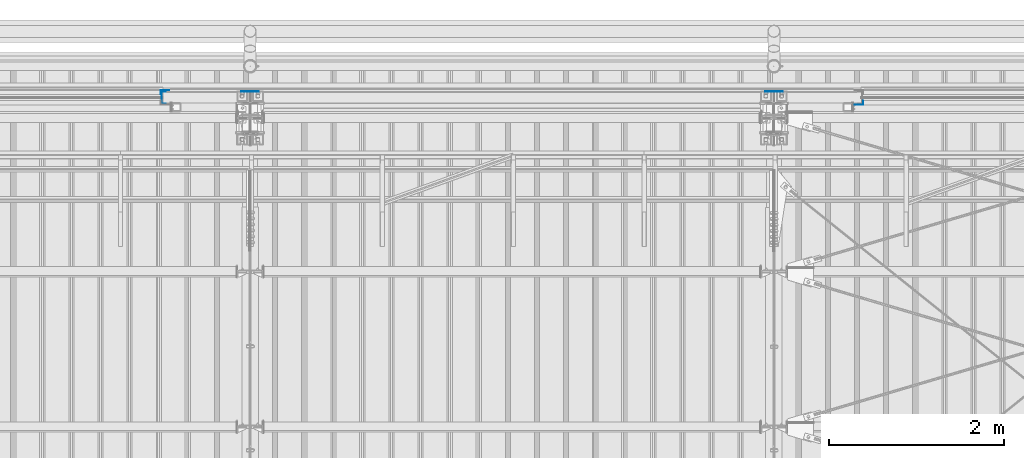
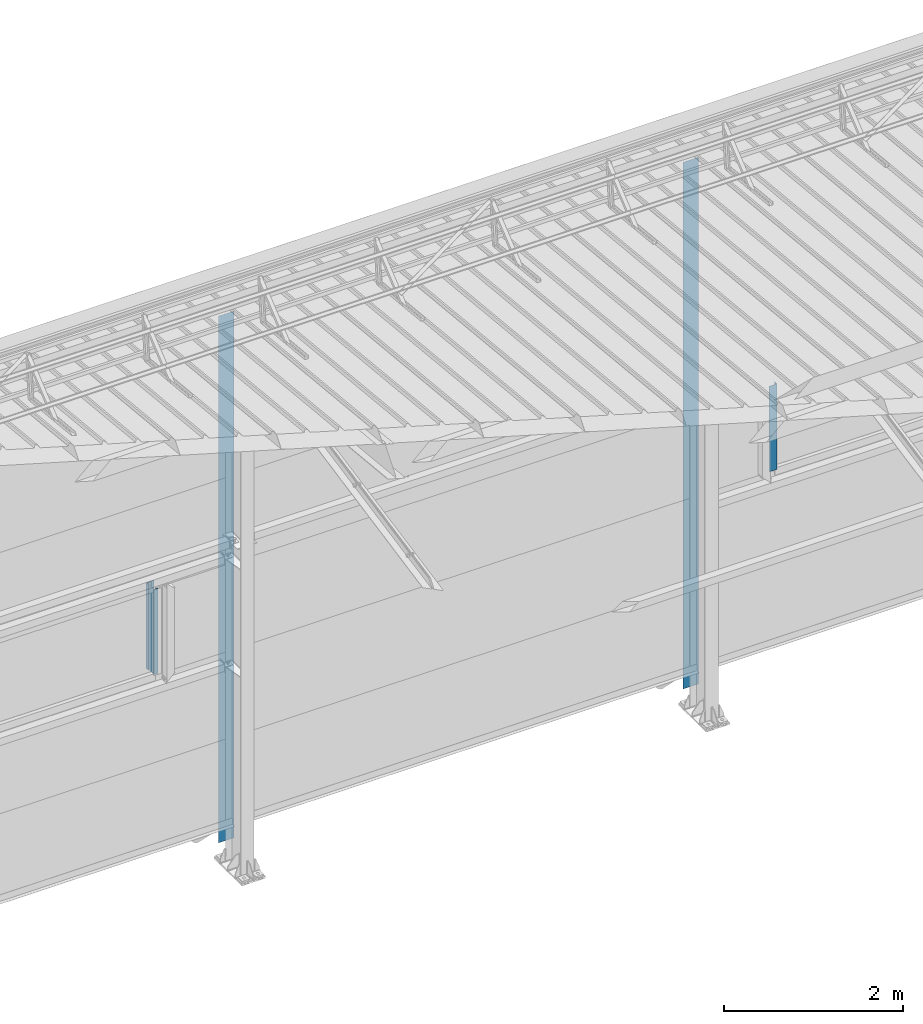
# One storey, part 15 of 709: 5 columns, 5 elements without a shape of their own.
"""IFC4 building model written with IfcOpenShell, lengths in millimetres."""

from ifc_helpers import new_model, si_unit, direction, frame, origin_with_axes, place, context, subcontext, project, spatial, line, indexed_curve, outline, extrude, material, element, aggregate, save


model = new_model("IFC4")

# Units and contexts
model_context = context("Model", 3, precision=0.2, world=origin_with_axes(), true_north=direction((0.0, 1.0)))
body_context = subcontext(model_context, "Body", "Model", "MODEL_VIEW")
ifc_project = project(units=[si_unit("LENGTHUNIT", "METRE", prefix="MILLI"), si_unit("AREAUNIT", "SQUARE_METRE"), si_unit("VOLUMEUNIT", "CUBIC_METRE"), si_unit("MASSUNIT", "GRAM", prefix="KILO"), si_unit("TIMEUNIT", "SECOND"), si_unit("PLANEANGLEUNIT", "RADIAN"), si_unit("SOLIDANGLEUNIT", "STERADIAN"), si_unit("THERMODYNAMICTEMPERATUREUNIT", "DEGREE_CELSIUS"), si_unit("LUMINOUSINTENSITYUNIT", "LUMEN")], contexts=[model_context])

# Site, building, storey
site_placement = place(None, origin_with_axes())
site = spatial("IfcSite", under=ifc_project, at=site_placement, CompositionType="ELEMENT")
building_placement = place(site_placement, origin_with_axes())
building = spatial("IfcBuilding", under=site, at=building_placement, Name="Undefined", CompositionType="ELEMENT")
storey_placement = place(building_placement, origin_with_axes())
storey = spatial("IfcBuildingStorey", under=building, at=storey_placement, Name="Undefined", CompositionType="ELEMENT", Elevation=0.0)

# Assembly, column
assembly_1_placement = place(storey_placement, frame((33010.0, 22060.0, 2700.0), z_axis=(0.0, -1.0, 0.0), x_axis=(0.0, 0.0, 1.0)))
assembly_1 = element("IfcElementAssembly", 1, at=assembly_1_placement, inside=storey)
ifc_material = material(Name="Steel_Undefined", Category="STEEL")
column_1_placement = place(assembly_1_placement, origin_with_axes())
column_1 = element("IfcColumn", 2, at=column_1_placement, material=ifc_material, context=body_context, shape_type="SolidModel", body=[
    extrude(outline(indexed_curve([(-70.0, -25.0), (-68.0, -25.0), (-68.0, 23.0), (68.0, 23.0), (68.0, -25.0), (70.0, -25.0), (70.0, 25.0), (-70.0, 25.0)], segments=[line(1, 2, 3, 4, 5, 6, 7, 8, 1)])), frame((0.0, 0.0, 0.0), z_axis=(-1.0, 0.0, 0.0), x_axis=(0.0, 0.0, 1.0)), (0.0, 0.0, -1.0), 1170.0),
])
aggregate(assembly_1, [column_1])

assembly_2_placement = place(storey_placement, frame((32975.0, 22121.0, 2700.0), z_axis=(0.0, 1.0, 0.0), x_axis=(0.0, 0.0, 1.0)))
assembly_2 = element("IfcElementAssembly", 3, at=assembly_2_placement, inside=storey)
column_2_placement = place(assembly_2_placement, origin_with_axes())
column_2 = element("IfcColumn", 4, at=column_2_placement, material=ifc_material, context=body_context, shape_type="SolidModel", body=[
    extrude(outline(indexed_curve([(-25.0, -1.0), (25.0, -1.0), (25.0, 99.0), (23.0, 99.0), (23.0, 1.0), (-25.0, 1.0)], segments=[line(1, 2, 3, 4, 5, 6, 1)])), frame((0.0, 0.0, 0.0), z_axis=(-1.0, 0.0, 0.0), x_axis=(0.0, 0.0, 1.0)), (0.0, 0.0, -1.0), 1170.0),
])
aggregate(assembly_2, [column_2])

assembly_3_placement = place(storey_placement, frame((41025.0, 22001.0, 2700.0), z_axis=(0.0, -1.0, 0.0), x_axis=(0.0, 0.0, 1.0)))
assembly_3 = element("IfcElementAssembly", 5, at=assembly_3_placement, inside=storey)
column_3_placement = place(assembly_3_placement, origin_with_axes())
column_3 = element("IfcColumn", 6, at=column_3_placement, material=ifc_material, context=body_context, shape_type="SolidModel", body=[
    extrude(outline(indexed_curve([(-25.0, -1.0), (25.0, -1.0), (25.0, 99.0), (23.0, 99.0), (23.0, 1.0), (-25.0, 1.0)], segments=[line(1, 2, 3, 4, 5, 6, 1)])), frame((0.0, 0.0, 0.0), z_axis=(-1.0, 0.0, 0.0), x_axis=(0.0, 0.0, 1.0)), (0.0, 0.0, -1.0), 1170.0),
])
aggregate(assembly_3, [column_3])

assembly_4_placement = place(storey_placement, frame((34000.0, 22130.0, 0.0), z_axis=(0.0, -1.0, 0.0), x_axis=(0.0, 0.0, 1.0)))
assembly_4 = element("IfcElementAssembly", 7, at=assembly_4_placement, inside=storey)
column_4_placement = place(assembly_4_placement, origin_with_axes())
column_4 = element("IfcColumn", 8, at=column_4_placement, material=ifc_material, context=body_context, shape_type="SolidModel", body=[
    extrude(outline(indexed_curve([(-0.375, -100.0), (1.245, -100.0), (1.245, -50.0), (0.495, -50.0), (0.495, -99.25), (0.375, -99.25), (0.375, 99.25), (0.495, 99.25), (0.495, 50.0), (1.245, 50.0), (1.245, 100.0), (-0.375, 100.0)], segments=[line(1, 2, 3, 4, 5, 6, 7, 8, 9, 10, 11, 12, 1)])), frame((0.0, 0.0, 0.0), z_axis=(-1.0, 0.0, 0.0), x_axis=(0.0, 0.0, 1.0)), (0.0, 0.0, -1.0), 7196.92297),
])
aggregate(assembly_4, [column_4])

assembly_5_placement = place(storey_placement, frame((40000.0, 22130.0, 0.0), z_axis=(0.0, -1.0, 0.0), x_axis=(0.0, 0.0, 1.0)))
assembly_5 = element("IfcElementAssembly", 9, at=assembly_5_placement, inside=storey)
column_5_placement = place(assembly_5_placement, origin_with_axes())
column_5 = element("IfcColumn", 10, at=column_5_placement, material=ifc_material, context=body_context, shape_type="SolidModel", body=[
    extrude(outline(indexed_curve([(-0.375, -100.0), (1.245, -100.0), (1.245, -50.0), (0.495, -50.0), (0.495, -99.25), (0.375, -99.25), (0.375, 99.25), (0.495, 99.25), (0.495, 50.0), (1.245, 50.0), (1.245, 100.0), (-0.375, 100.0)], segments=[line(1, 2, 3, 4, 5, 6, 7, 8, 9, 10, 11, 12, 1)])), frame((0.0, 0.0, 0.0), z_axis=(-1.0, 0.0, 0.0), x_axis=(0.0, 0.0, 1.0)), (0.0, 0.0, -1.0), 7196.92297),
])
aggregate(assembly_5, [column_5])

save(model, "model.ifc")
